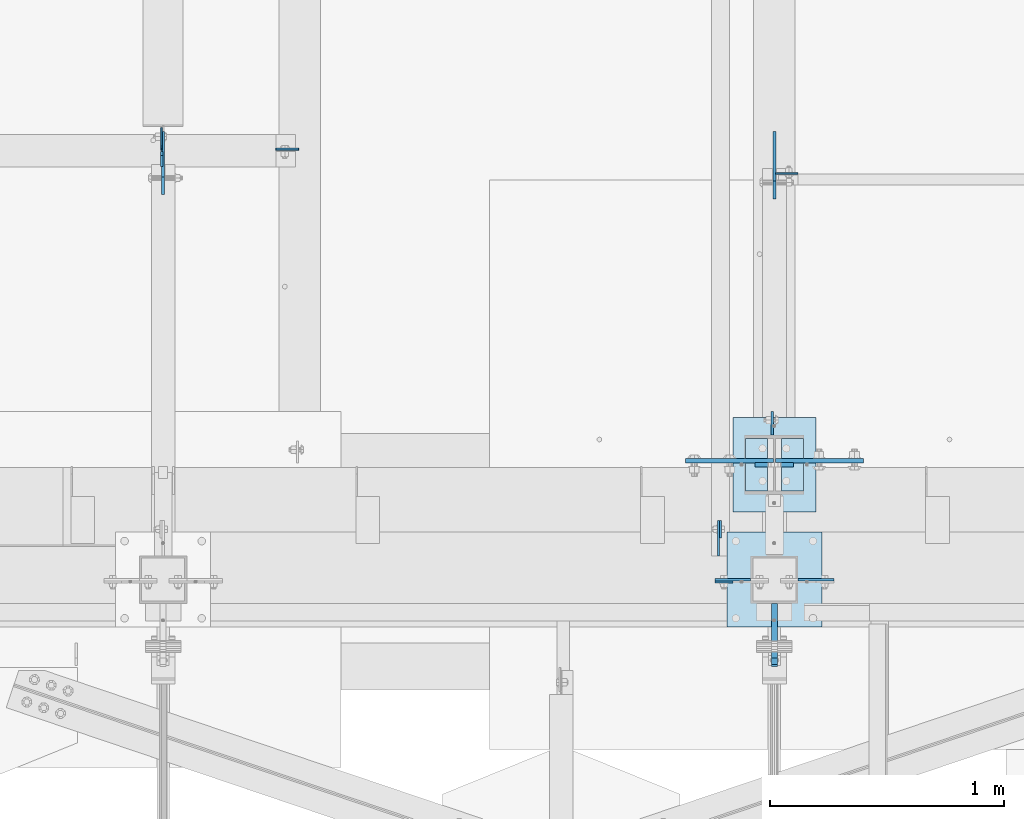
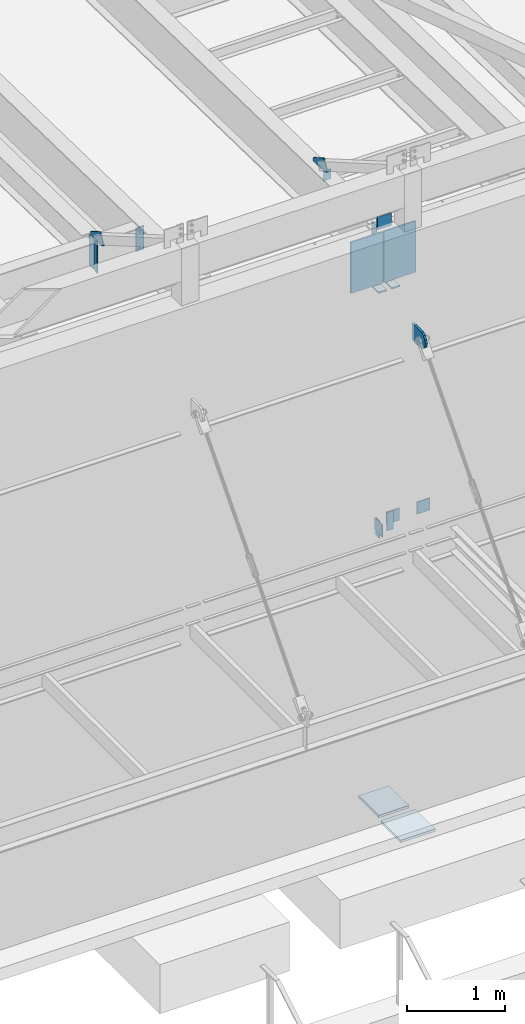
# One storey, part 1468 of 1763: 20 plates, 7 elements without a shape of their own.
"""IFC2X3 building model written with IfcOpenShell, lengths in millimetres."""

from ifc_helpers import new_model, si_unit, frame, origin_with_axes, place, context, subcontext, project, spatial, faceted_brep, material, type_object, element, aggregate, save


model = new_model("IFC2X3")

# Units and contexts
model_context = context("Model", 3, precision=1e-05, world=origin_with_axes())
body_context = subcontext(model_context, "Body", "Model", "MODEL_VIEW")
ifc_project = project(units=[si_unit("LENGTHUNIT", "METRE", prefix="MILLI"), si_unit("AREAUNIT", "SQUARE_METRE"), si_unit("VOLUMEUNIT", "CUBIC_METRE"), si_unit("MASSUNIT", "GRAM", prefix="KILO"), si_unit("TIMEUNIT", "SECOND"), si_unit("PLANEANGLEUNIT", "RADIAN"), si_unit("SOLIDANGLEUNIT", "STERADIAN"), si_unit("THERMODYNAMICTEMPERATUREUNIT", "DEGREE_CELSIUS"), si_unit("LUMINOUSINTENSITYUNIT", "LUMEN")], contexts=[model_context])

# Site, building, storey
site_placement = place(None, origin_with_axes())
site = spatial("IfcSite", under=ifc_project, at=site_placement, CompositionType="ELEMENT")
building_placement = place(site_placement, origin_with_axes())
building = spatial("IfcBuilding", under=site, at=building_placement, Name="Undefined", CompositionType="ELEMENT")
storey_placement = place(building_placement, origin_with_axes())
storey = spatial("IfcBuildingStorey", under=building, at=storey_placement, Name="Undefined", CompositionType="ELEMENT", Elevation=0.0)

# Assembly, plate
assembly_1_placement = place(storey_placement, origin_with_axes())
assembly_1 = element("IfcElementAssembly", 1, at=assembly_1_placement, inside=storey, Name="BEAM", AssemblyPlace="NOTDEFINED", PredefinedType="RIGID_FRAME")
ifc_material_1 = material(Name="STEEL/A36")
plate_type_1 = type_object("IfcPlateType", PredefinedType="NOTDEFINED")
plate_1_placement = place(assembly_1_placement, frame((-49580.227020257, -14217.6525763242, 8839.2), z_axis=(0.0, 0.0, 1.0), x_axis=(-1.0, 0.0, 0.0)))
plate_1 = element("IfcPlate", 2, at=plate_1_placement, type_object=plate_type_1, material=ifc_material_1, Name="PLATE", context=body_context, shape_type="Brep", body=[
    faceted_brep([(0.0, -4.76249999999982, 0.0), (-2.83762346953154e-10, -4.7624999996915, 228.600006103516), (-2.83762346953154e-10, 4.76250000028813, 228.600006103517), (0.0, 4.76249999999982, 0.0), (76.1999969480166, -4.76249999961874, 228.600006103516), (76.1999969480166, 4.76250000036089, 228.600006103517), (76.1999969482931, -4.76249999991705, 0.0), (76.1999969482931, 4.76250000006257, 1.81898940354586e-12)], [[[0, 1, 2, 3]], [[1, 4, 5, 2]], [[4, 6, 7, 5]], [[6, 0, 3, 7]], [[5, 7, 3, 2]], [[6, 4, 1, 0]]]),
])

assembly_2_placement = place(storey_placement, origin_with_axes())
assembly_2 = element("IfcElementAssembly", 3, at=assembly_2_placement, inside=storey, Name="BEAM", AssemblyPlace="NOTDEFINED", PredefinedType="RIGID_FRAME")
plate_2_placement = place(assembly_2_placement, frame((-49632.6587013228, -14030.314902539, 8623.30000007624), z_axis=(0.0, 0.0, 1.0), x_axis=(0.0, 1.0, 0.0)))
plate_2 = element("IfcPlate", 4, at=plate_2_placement, type_object=plate_type_1, material=ifc_material_1, Name="PLATE", context=body_context, shape_type="Brep", body=[
    faceted_brep([(0.0, -4.76249999999982, 0.0), (0.0294800233077694, -4.76250000068103, 215.899993896486), (0.0294800233114074, 4.76249999931315, 215.899993896483), (0.0, 4.76249999999982, 0.0), (76.2294769287091, -4.76250000057917, 215.899993896486), (76.2294769287128, 4.76249999942229, 215.899993896483), (76.1999969482931, -4.76249999991705, 0.0), (76.1999969482931, 4.76250000006257, 1.81898940354586e-12)], [[[0, 1, 2, 3]], [[1, 4, 5, 2]], [[4, 6, 7, 5]], [[6, 0, 3, 7]], [[5, 7, 3, 2]], [[6, 4, 1, 0]]]),
])
aggregate(assembly_2, [plate_2])

# Assembly, plates
assembly_3_placement = place(storey_placement, origin_with_axes())
assembly_3 = element("IfcElementAssembly", 5, at=assembly_3_placement, inside=storey, Name="COLUMN", AssemblyPlace="NOTDEFINED", PredefinedType="RIGID_FRAME")
plate_type_2 = type_object("IfcPlateType", PredefinedType="NOTDEFINED")
plate_3_placement = place(assembly_3_placement, frame((-49656.4270172529, -14208.127577824, 9067.80000610352), z_axis=(0.0, 0.0, -1.0), x_axis=(1.0, 0.0, 0.0)))
plate_3 = element("IfcPlate", 6, at=plate_3_placement, type_object=plate_type_2, material=ifc_material_1, Name="PLATE", context=body_context, shape_type="Brep", body=[
    faceted_brep([(0.0, -4.76249999999982, 0.0), (-3.05175672110636e-06, -4.7625000002663, 152.399993896484), (-3.05175490211695e-06, 4.76249999972788, 152.399993896484), (0.0, 4.76249999999982, 0.0), (152.400009155272, -4.76249999975698, 152.399993896484), (152.400009155273, 4.76250000024447, 152.399993896484), (152.400009155272, -4.76249999948777, 5.45696821063757e-12), (152.400009155273, 4.76250000051368, 3.63797880709171e-12)], [[[0, 1, 2, 3]], [[1, 4, 5, 2]], [[4, 6, 7, 5]], [[6, 0, 3, 7]], [[5, 7, 3, 2]], [[6, 4, 1, 0]]]),
])
plate_4_placement = place(assembly_3_placement, frame((-49148.426999389, -14208.1275752824, 9067.80000610352), z_axis=(0.0, 0.0, -1.0), x_axis=(-1.0, 0.0, 0.0)))
plate_4 = element("IfcPlate", 7, at=plate_4_placement, type_object=plate_type_2, material=ifc_material_1, Name="PLATE", context=body_context, shape_type="Brep", body=[
    faceted_brep([(0.0, -4.76249999999982, 0.0), (-3.05175672110636e-06, -4.7625000002663, 152.399993896484), (-3.05175490211695e-06, 4.76249999972788, 152.399993896484), (0.0, 4.76249999999982, 0.0), (152.400009155272, -4.76249999975698, 152.399993896484), (152.400009155273, 4.76250000024447, 152.399993896484), (152.400009155272, -4.76249999948777, 5.45696821063757e-12), (152.400009155273, 4.76250000051368, 3.63797880709171e-12)], [[[0, 1, 2, 3]], [[1, 4, 5, 2]], [[4, 6, 7, 5]], [[6, 0, 3, 7]], [[5, 7, 3, 2]], [[6, 4, 1, 0]]]),
])

# Plate
plate_5_placement = place(assembly_1_placement, frame((-49642.1837033244, -13954.0854255189, 8839.19999998095), z_axis=(0.0, 0.0, -1.0), x_axis=(0.0, -1.0, 0.0)))
plate_5 = element("IfcPlate", 8, at=plate_5_placement, type_object=plate_type_2, material=ifc_material_1, Name="PLATE", context=body_context, shape_type="Brep", body=[
    faceted_brep([(0.0, -4.76249999999982, 0.0), (-3.05175672110636e-06, -4.7625000002663, 152.399993896484), (-3.05175490211695e-06, 4.76249999972788, 152.399993896484), (0.0, 4.76249999999982, 0.0), (152.400009155272, -4.76249999975698, 152.399993896484), (152.400009155273, 4.76250000024447, 152.399993896484), (152.400009155272, -4.76249999948777, 5.45696821063757e-12), (152.400009155273, 4.76250000051368, 3.63797880709171e-12)], [[[0, 1, 2, 3]], [[1, 4, 5, 2]], [[4, 6, 7, 5]], [[6, 0, 3, 7]], [[5, 7, 3, 2]], [[6, 4, 1, 0]]]),
])

aggregate(assembly_1, [plate_1, plate_5])

# Assembly, plate
assembly_4_placement = place(storey_placement, origin_with_axes())
assembly_4 = element("IfcElementAssembly", 9, at=assembly_4_placement, inside=storey, Name="BEAM", AssemblyPlace="NOTDEFINED", PredefinedType="RIGID_FRAME")
plate_type_3 = type_object("IfcPlateType", PredefinedType="NOTDEFINED")
plate_6_placement = place(assembly_4_placement, frame((-49397.6747736984, -12468.6187192313, 12153.2886368765), z_axis=(1.0, 0.0, 0.0), x_axis=(0.0, 0.0, -1.0)))
plate_6 = element("IfcPlate", 10, at=plate_6_placement, type_object=plate_type_3, material=ifc_material_1, Name="PLATE", context=body_context, shape_type="Brep", body=[
    faceted_brep([(1.81898940354586e-12, -3.17500000000291, 0.0), (0.0, -3.17499999999927, 95.25), (0.0, 3.17499999999927, 95.25), (-1.81898940354586e-12, 3.17499999997381, 0.0), (127.0, -3.17499999999927, 95.25), (127.0, 3.17499999999927, 95.25), (127.0, -3.17499999999927, 0.0), (127.0, 3.17499999999927, 0.0)], [[[0, 1, 2, 3]], [[1, 4, 5, 2]], [[4, 6, 7, 5]], [[6, 0, 3, 7]], [[5, 7, 3, 2]], [[6, 4, 1, 0]]]),
])

assembly_5_placement = place(storey_placement, origin_with_axes())
assembly_5 = element("IfcElementAssembly", 11, at=assembly_5_placement, inside=storey, Name="BEAM", AssemblyPlace="NOTDEFINED", PredefinedType="RIGID_FRAME")
plate_7_placement = place(assembly_5_placement, frame((-52024.987273746, -12368.9394876504, 11786.0798333454), z_axis=(0.0, 0.0, 1.0), x_axis=(0.0, 1.0, 0.0)))
plate_7 = element("IfcPlate", 12, at=plate_7_placement, type_object=plate_type_3, material=ifc_material_1, Name="PLATE", context=body_context, shape_type="Brep", body=[
    faceted_brep([(0.0, -3.17500000000291, 17.4624996185303), (0.0, -3.17500000000291, 363.53750038147), (0.0, 3.17500000000291, 363.53750038147), (0.0, 3.17500000000291, 17.4624996185303), (17.4624996185303, -3.17500000000291, 381.0), (17.4624996185303, 3.17500000000291, 381.0), (95.25, -3.17500000000291, 381.0), (95.25, 3.17500000000291, 381.0), (95.25, -3.17500000000291, 0.0), (95.25, 3.17500000000291, 0.0), (17.4624996185303, -3.17500000000291, 0.0), (17.4624996185303, 3.17500000000291, 0.0)], [[[0, 1, 2, 3]], [[1, 4, 5, 2]], [[4, 6, 7, 5]], [[6, 8, 9, 7]], [[8, 10, 11, 9]], [[10, 0, 3, 11]], [[5, 7, 9, 11, 3, 2]], [[10, 8, 6, 4, 1, 0]]]),
])

# Plate
plate_type_4 = type_object("IfcPlateType", PredefinedType="NOTDEFINED")
plate_8_placement = place(assembly_3_placement, frame((-49402.4270098553, -14503.4026217454, 11188.7000003081), z_axis=(0.0, 0.0, 1.0), x_axis=(0.0, 1.0, 0.0)))
plate_8 = element("IfcPlate", 13, at=plate_8_placement, type_object=plate_type_4, material=ifc_material_1, Name="PLATE", context=body_context, shape_type="Brep", body=[
    faceted_brep([(0.0, -12.6999999999971, -1.81898940354586e-12), (-39.5764506670585, -12.6999999999971, 21.5331529121049), (-39.5764506670585, 12.6999999999971, 21.5331529121049), (0.0, 12.6999999999971, -1.81898940354586e-12), (-66.6095773920388, -12.6999999999971, 57.5773227764421), (-66.6095773920388, 12.6999999999971, 57.5773227764421), (-76.199996948335, -12.6999999999971, 101.599998461508), (-76.199996948335, 12.6999999999971, 101.599998461508), (-66.6095774066125, -12.6999999999971, 145.622674149748), (-66.6095774066125, 12.6999999999971, 145.622674149748), (-39.5764506935648, -12.6999999999971, 181.666844023039), (-39.5764506935648, 12.6999999999971, 181.666844023039), (-3.36349330609664e-08, -12.6999999999971, 203.199996948242), (-3.36349330609664e-08, 12.6999999999971, 203.199996948242), (193.675003051578, -12.6999999999971, 203.199996948413), (193.675003051578, 12.6999999999971, 203.199996948413), (193.675003051758, -12.6999999999971, 3.09228198602796e-10), (193.675003051758, 12.6999999999971, 3.09228198602796e-10)], [[[0, 1, 2, 3]], [[1, 4, 5, 2]], [[4, 6, 7, 5]], [[6, 8, 9, 7]], [[8, 10, 11, 9]], [[10, 12, 13, 11]], [[12, 14, 15, 13]], [[14, 16, 17, 15]], [[16, 0, 3, 17]], [[5, 7, 9, 11, 13, 15, 17, 3, 2]], [[16, 14, 12, 10, 8, 6, 4, 1, 0]]]),
])

# Assembly, plate
assembly_6_placement = place(storey_placement, origin_with_axes())
assembly_6 = element("IfcElementAssembly", 14, at=assembly_6_placement, inside=storey, Name="COLUMN", AssemblyPlace="NOTDEFINED", PredefinedType="RIGID_FRAME")
ifc_material_2 = material(Name="STEEL/A572-50")
plate_type_5 = type_object("IfcPlateType", PredefinedType="NOTDEFINED")
plate_9_placement = place(assembly_6_placement, frame((-49319.8872721725, -13715.9998186171, 12369.7999938965), z_axis=(0.0, 0.0, -1.0), x_axis=(-1.0, 0.0, 0.0)))
plate_9 = element("IfcPlate", 15, at=plate_9_placement, type_object=plate_type_5, material=ifc_material_2, Name="PLATE", context=body_context, shape_type="Brep", body=[
    faceted_brep([(7.27595761418343e-12, 9.52500000000146, 155.574990844727), (-1.45519152283669e-11, 7.27595761418343e-12, 165.099990844727), (165.099990844727, 0.0, 165.099990844727), (165.099990844727, 9.52500000000146, 155.574990844727), (-3.63797880709171e-11, -9.5249999999869, 155.574990844727), (165.099990844727, -9.52500000000146, 155.574990844727), (0.0, 9.52500000000146, 0.0), (0.0, -9.52500000000146, 0.0), (165.099990844727, -9.52500000000146, 0.0), (165.099990844727, 9.52500000000146, 0.0)], [[[0, 1, 2, 3]], [[1, 4, 5, 2]], [[6, 7, 4, 1, 0]], [[5, 8, 9, 3, 2]], [[8, 7, 6, 9]], [[9, 6, 0, 3]], [[7, 8, 5, 4]]]),
])

# Plate
plate_type_6 = type_object("IfcPlateType", PredefinedType="NOTDEFINED")
plate_10_placement = place(assembly_4_placement, frame((-49402.4377736144, -12289.5645130616, 12174.8790507221), z_axis=(0.0, -1.0, 0.0), x_axis=(0.0, 0.0, 1.0)))
plate_10 = element("IfcPlate", 16, at=plate_10_placement, type_object=plate_type_6, material=ifc_material_1, Name="PLATE", context=body_context, shape_type="Brep", body=[
    faceted_brep([(0.0, -6.34999999999491, 1.45519152283669e-11), (3.45059657096863, -6.34999999999854, 165.063949584961), (3.45059657096863, 6.34999999999854, 165.063949584961), (0.0, 6.34999999999491, -2.91038304567337e-11), (5.01950931549072, -6.34999999999854, 240.10026550293), (5.01950931549072, 6.34999999999854, 240.10026550293), (33.3607749938965, -6.34999999999854, 288.962707519531), (33.3607749938965, 6.34999999999854, 288.962707519531), (165.188125610352, -6.34999999999854, 212.500045776367), (165.188125610352, 6.34999999999854, 212.500045776367), (41.9335784912109, -6.34999999999854, 0.0), (41.9335784912109, 6.34999999999854, 0.0)], [[[0, 1, 2, 3]], [[1, 4, 5, 2]], [[4, 6, 7, 5]], [[6, 8, 9, 7]], [[8, 10, 11, 9]], [[10, 0, 3, 11]], [[5, 7, 9, 11, 3, 2]], [[10, 8, 6, 4, 1, 0]]]),
])

aggregate(assembly_4, [plate_6, plate_10])

plate_11_placement = place(assembly_5_placement, frame((-52018.6377736144, -12289.5644555728, 12176.6048333467), z_axis=(0.0, -1.0, 0.0), x_axis=(0.0, 0.0, 1.0)))
plate_11 = element("IfcPlate", 17, at=plate_11_placement, type_object=plate_type_6, material=ifc_material_1, Name="PLATE", context=body_context, shape_type="Brep", body=[
    faceted_brep([(0.0, -6.34999999999491, 1.45519152283669e-11), (0.0, -6.34999999999854, 165.100006103516), (0.0, 6.34999999999854, 165.100006103516), (0.0, 6.34999999999491, -2.91038304567337e-11), (0.0, -6.34999999999854, 234.421340942383), (0.0, 6.34999999999854, 234.421340942383), (20.8898239135742, -6.34999999999854, 270.436950683594), (20.8898239135742, 6.34999999999854, 270.436950683594), (152.717071533203, -6.34999999999854, 193.974349975586), (152.717071533203, 6.34999999999854, 193.974349975586), (40.2078170776367, -6.34999999999854, 0.0), (40.2078170776367, 6.34999999999854, 0.0)], [[[0, 1, 2, 3]], [[1, 4, 5, 2]], [[4, 6, 7, 5]], [[6, 8, 9, 7]], [[8, 10, 11, 9]], [[10, 0, 3, 11]], [[5, 7, 9, 11, 3, 2]], [[10, 8, 6, 4, 1, 0]]]),
])

plate_type_7 = type_object("IfcPlateType", PredefinedType="NOTDEFINED")
plate_12_placement = place(assembly_6_placement, frame((-49411.9622736983, -13588.9999999999, 12162.6007728232), z_axis=(0.0, 1.0, 0.0), x_axis=(0.0, 0.0, -1.0)))
plate_12 = element("IfcPlate", 18, at=plate_12_placement, type_object=plate_type_7, material=ifc_material_1, Name="PLATE", context=body_context, shape_type="Brep", body=[
    faceted_brep([(0.0, -4.76249999999982, 0.0), (1.45519152283669e-11, -4.76250000000448, 101.60001373291), (0.0, 4.76250000000243, 101.60001373291), (0.0, 4.76249999999982, 0.0), (533.400024414062, -4.76249999999709, 101.599998474121), (533.400024414062, 4.76249999999709, 101.599998474121), (533.400024414062, -4.76250000000073, 0.0), (533.400024414062, 4.76250000000073, 0.0)], [[[0, 1, 2, 3]], [[1, 4, 5, 2]], [[4, 6, 7, 5]], [[6, 0, 3, 7]], [[5, 7, 3, 2]], [[6, 4, 1, 0]]]),
])

# Assembly, plate
assembly_7_placement = place(storey_placement, origin_with_axes())
assembly_7 = element("IfcElementAssembly", 19, at=assembly_7_placement, inside=storey, Name="BEAM", AssemblyPlace="NOTDEFINED", PredefinedType="RIGID_FRAME")
plate_type_8 = type_object("IfcPlateType", PredefinedType="NOTDEFINED")
plate_13_placement = place(assembly_7_placement, frame((-51439.1997736983, -12364.9704876481, 12132.1548333448), z_axis=(-1.0, 0.0, 0.0), x_axis=(0.0, 0.0, -1.0)))
plate_13 = element("IfcPlate", 20, at=plate_13_placement, type_object=plate_type_8, material=ifc_material_1, Name="PLATE", context=body_context, shape_type="Brep", body=[
    faceted_brep([(0.0, -3.96900000000096, 0.0), (0.0, -3.96899999999914, 96.8375015258789), (0.0, 3.96899999999914, 96.8375015258789), (0.0, 3.96900000000096, 0.0), (292.100006103516, -3.96899999999914, 96.8375015258789), (292.100006103516, 3.96899999999914, 96.8375015258789), (292.100006103516, -3.96899999999914, 0.0), (292.100006103516, 3.96899999999914, 0.0)], [[[0, 1, 2, 3]], [[1, 4, 5, 2]], [[4, 6, 7, 5]], [[6, 0, 3, 7]], [[5, 7, 3, 2]], [[6, 4, 1, 0]]]),
])
aggregate(assembly_7, [plate_13])

# Plate
plate_type_9 = type_object("IfcPlateType", PredefinedType="NOTDEFINED")
plate_14_placement = place(assembly_5_placement, frame((-52024.9877736144, -12375.2894876504, 11786.0798333454), z_axis=(0.0, 0.0, 1.0), x_axis=(0.0, -1.0, 0.0)))
plate_14 = element("IfcPlate", 21, at=plate_14_placement, type_object=plate_type_9, material=ifc_material_1, Name="PLATE", context=body_context, shape_type="Brep", body=[
    faceted_brep([(0.0, -4.76249999999709, 17.4624996185303), (0.0, -4.76249999999709, 363.53750038147), (0.0, 4.76249999999709, 363.53750038147), (0.0, 4.76249999999709, 17.4624996185303), (17.4624996185303, -4.76249999999709, 381.0), (17.4624996185303, 4.76249999999709, 381.0), (63.5, -4.76249999999709, 381.0), (63.5, 4.76249999999709, 381.0), (63.4999999999964, -4.76250000017171, 0.0), (63.5000000000036, 4.76249999982974, 0.0), (17.4624996185303, -4.76249999999709, 0.0), (17.4624996185303, 4.76249999999709, 0.0)], [[[0, 1, 2, 3]], [[1, 4, 5, 2]], [[4, 6, 7, 5]], [[6, 8, 9, 7]], [[8, 10, 11, 9]], [[10, 0, 3, 11]], [[5, 7, 9, 11, 3, 2]], [[10, 8, 6, 4, 1, 0]]]),
])

aggregate(assembly_5, [plate_11, plate_14, plate_7])

plate_type_10 = type_object("IfcPlateType", PredefinedType="NOTDEFINED")
plate_15_placement = place(assembly_6_placement, frame((-49398.4685236983, -13698.5373186171, 12153.9), z_axis=(1.0, 0.0, 0.0), x_axis=(0.0, 0.0, -1.0)))
plate_15 = element("IfcPlate", 22, at=plate_15_placement, type_object=plate_type_10, material=ifc_material_2, Name="PLATE", context=body_context, shape_type="Brep", body=[
    faceted_brep([(0.0, -9.52500000000146, 0.0), (0.0, -9.52499999999964, 377.03125), (0.0, 9.52499999999964, 377.03125), (0.0, 9.52500000000146, 0.0), (635.0, -9.52499999999964, 377.03125), (635.0, 9.52499999999964, 377.03125), (635.0, -9.52499999999964, 0.0), (635.0, 9.52499999999964, 0.0)], [[[0, 1, 2, 3]], [[1, 4, 5, 2]], [[4, 6, 7, 5]], [[6, 0, 3, 7]], [[5, 7, 3, 2]], [[6, 4, 1, 0]]]),
])

plate_16_placement = place(assembly_6_placement, frame((-49406.4060236983, -13699.3310686171, 12153.9), z_axis=(-1.0, 0.0, 0.0), x_axis=(0.0, 0.0, -1.0)))
plate_16 = element("IfcPlate", 23, at=plate_16_placement, type_object=plate_type_10, material=ifc_material_2, Name="PLATE", context=body_context, shape_type="Brep", body=[
    faceted_brep([(0.0, -9.52500000000146, 0.0), (0.0, -9.52499999999964, 377.03125), (0.0, 9.52499999999964, 377.03125), (0.0, 9.52500000000146, 0.0), (635.0, -9.52499999999964, 377.03125), (635.0, 9.52499999999964, 377.03125), (635.0, -9.52499999999964, 0.0), (635.0, 9.52499999999964, 0.0)], [[[0, 1, 2, 3]], [[1, 4, 5, 2]], [[4, 6, 7, 5]], [[6, 0, 3, 7]], [[5, 7, 3, 2]], [[6, 4, 1, 0]]]),
])

plate_type_11 = type_object("IfcPlateType", PredefinedType="NOTDEFINED")
plate_17_placement = place(assembly_6_placement, frame((-49580.2372736984, -13512.8, 5083.17499999999), z_axis=(1.0, 0.0, 0.0), x_axis=(0.0, -1.0, 0.0)))
plate_17 = element("IfcPlate", 24, at=plate_17_placement, type_object=plate_type_11, material=ifc_material_1, Name="PLATE", context=body_context, shape_type="Brep", body=[
    faceted_brep([(0.0, -15.875, 0.0), (0.0, -15.875, 355.600006103516), (0.0, 15.875, 355.600006103516), (0.0, 15.875, 0.0), (406.399993896484, -15.875, 355.600006103516), (406.399993896484, 15.875, 355.600006103516), (406.399993896484, -15.875, 0.0), (406.399993896484, 15.875, 0.0)], [[[0, 1, 2, 3]], [[1, 4, 5, 2]], [[4, 6, 7, 5]], [[6, 0, 3, 7]], [[5, 7, 3, 2]], [[6, 4, 1, 0]]]),
])

plate_type_12 = type_object("IfcPlateType", PredefinedType="NOTDEFINED")
plate_18_placement = place(assembly_6_placement, frame((-49277.8185236983, -13828.7125, 11509.375), z_axis=(0.0, 1.0, 0.0), x_axis=(-1.0, 0.0, 0.0)))
plate_18 = element("IfcPlate", 25, at=plate_18_placement, type_object=plate_type_12, material=ifc_material_1, Name="PLATE", context=body_context, shape_type="Brep", body=[
    faceted_brep([(0.0, -9.52500000000146, 0.0), (0.0, -9.52499999999964, 225.425003051758), (0.0, 9.52499999999964, 225.425003051758), (0.0, 9.52500000000146, 0.0), (95.25, -9.52499999999964, 225.425003051758), (95.25, 9.52499999999964, 225.425003051758), (95.2499921933502, -9.52499999999964, 0.0), (95.2499921933502, 9.52499999999964, 0.0)], [[[0, 1, 2, 3]], [[1, 4, 5, 2]], [[4, 6, 7, 5]], [[0, 3, 7, 6]], [[5, 7, 3, 2]], [[6, 4, 1, 0]]]),
])

plate_19_placement = place(assembly_6_placement, frame((-49527.0560236984, -13603.2875, 11509.375), z_axis=(0.0, -1.0, 0.0), x_axis=(1.0, 0.0, 0.0)))
plate_19 = element("IfcPlate", 26, at=plate_19_placement, type_object=plate_type_12, material=ifc_material_1, Name="PLATE", context=body_context, shape_type="Brep", body=[
    faceted_brep([(0.0, -9.52500000000146, 0.0), (0.0, -9.52499999999964, 225.425003051758), (0.0, 9.52499999999964, 225.425003051758), (0.0, 9.52500000000146, 0.0), (95.25, -9.52499999999964, 225.425003051758), (95.25, 9.52499999999964, 225.425003051758), (95.2499921933502, -9.52499999999964, 0.0), (95.2499921933502, 9.52499999999964, 0.0)], [[[0, 1, 2, 3]], [[1, 4, 5, 2]], [[4, 6, 7, 5]], [[0, 3, 7, 6]], [[5, 7, 3, 2]], [[6, 4, 1, 0]]]),
])

aggregate(assembly_6, [plate_9, plate_12, plate_18, plate_15, plate_19, plate_16, plate_17])

plate_type_13 = type_object("IfcPlateType", PredefinedType="NOTDEFINED")
plate_20_placement = place(assembly_3_placement, frame((-49605.6270083209, -14004.9276214144, 5083.17499999999), z_axis=(1.0, 0.0, 0.0), x_axis=(0.0, -1.0, 0.0)))
plate_20 = element("IfcPlate", 27, at=plate_20_placement, type_object=plate_type_13, material=ifc_material_1, Name="PLATE", context=body_context, shape_type="Brep", body=[
    faceted_brep([(0.0, -15.875, 0.0), (0.0, -15.875, 406.399993896484), (0.0, 15.875, 406.399993896484), (0.0, 15.875, 0.0), (406.399993896484, -15.875, 406.399993896484), (406.399993896484, 15.875, 406.399993896484), (406.399993896484, -15.875, 0.0), (406.399993896484, 15.875, 0.0)], [[[0, 1, 2, 3]], [[1, 4, 5, 2]], [[4, 6, 7, 5]], [[6, 0, 3, 7]], [[5, 7, 3, 2]], [[6, 4, 1, 0]]]),
])

aggregate(assembly_3, [plate_3, plate_4, plate_8, plate_20])

save(model, "model.ifc")
